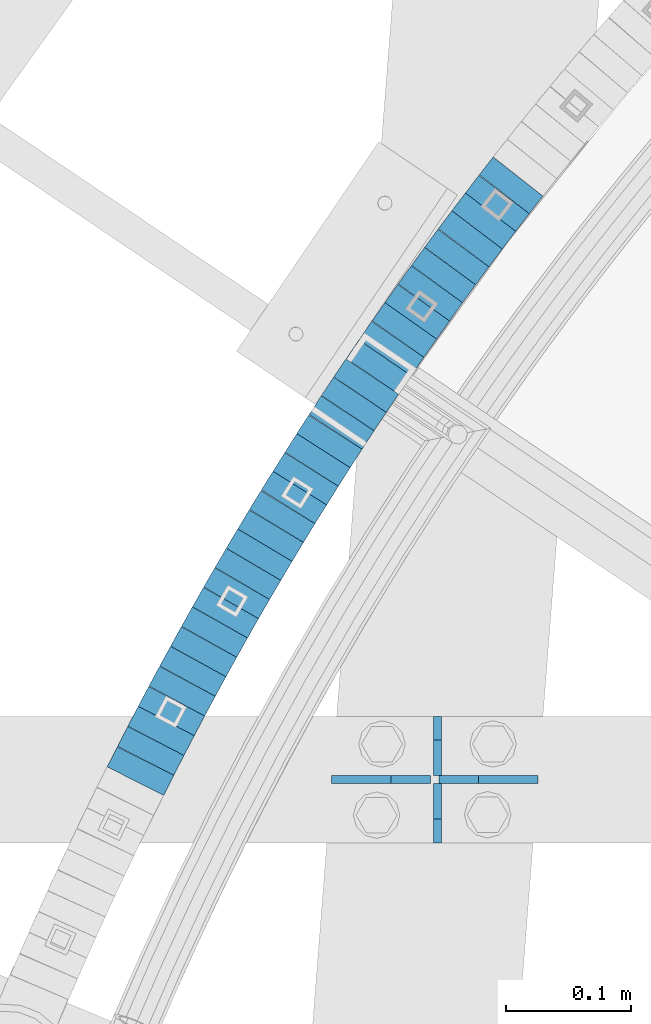
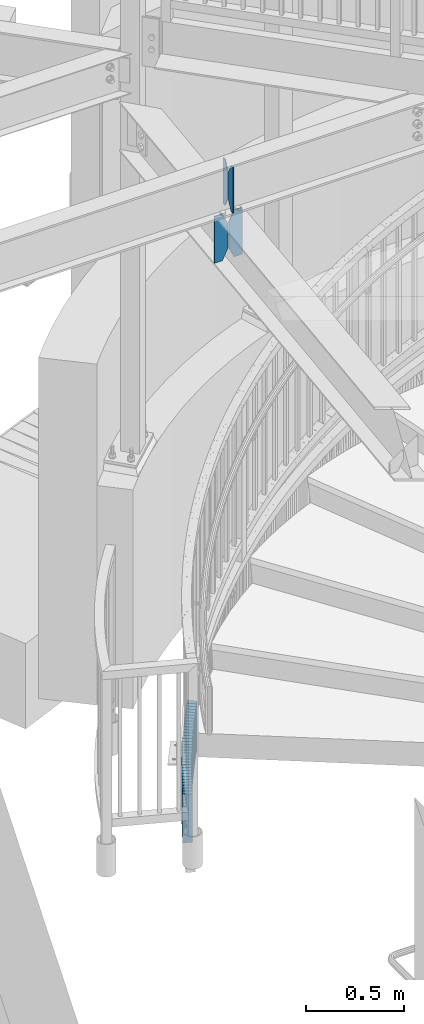
# One storey, part 890 of 975: 36 plates.
"""IFC2X3 building model written with IfcOpenShell, lengths in millimetres."""

from ifc_helpers import new_model, si_unit, frame, origin_with_axes, place, context, subcontext, project, spatial, faceted_brep, material, type_object, element, save


model = new_model("IFC2X3")

# Units and contexts
model_context = context("Model", 3, precision=1e-05, world=origin_with_axes())
body_context = subcontext(model_context, "Body", "Model", "MODEL_VIEW")
ifc_project = project(units=[si_unit("LENGTHUNIT", "METRE", prefix="MILLI"), si_unit("AREAUNIT", "SQUARE_METRE"), si_unit("VOLUMEUNIT", "CUBIC_METRE"), si_unit("MASSUNIT", "GRAM", prefix="KILO"), si_unit("TIMEUNIT", "SECOND"), si_unit("PLANEANGLEUNIT", "RADIAN"), si_unit("SOLIDANGLEUNIT", "STERADIAN"), si_unit("THERMODYNAMICTEMPERATUREUNIT", "DEGREE_CELSIUS"), si_unit("LUMINOUSINTENSITYUNIT", "LUMEN")], contexts=[model_context])

# Site, building, storey
site_placement = place(None, origin_with_axes())
site = spatial("IfcSite", under=ifc_project, at=site_placement, CompositionType="ELEMENT")
building_placement = place(site_placement, origin_with_axes())
building = spatial("IfcBuilding", under=site, at=building_placement, Name="Undefined", CompositionType="ELEMENT")
storey_placement = place(building_placement, origin_with_axes())
storey = spatial("IfcBuildingStorey", under=building, at=storey_placement, Name="Undefined", CompositionType="ELEMENT", Elevation=0.0)

# Plates
ifc_material = material(Name="STEEL/A36")
plate_type_1 = type_object("IfcPlateType", PredefinedType="NOTDEFINED")
plate_1_placement = place(storey_placement, frame((32412.0742550578, 4641.849609375, 3636.9625), z_axis=(0.0, 0.0, 1.0), x_axis=(0.0, 1.0, 0.0)))
element("IfcPlate", 1, at=plate_1_placement, inside=storey, type_object=plate_type_1, material=ifc_material, Name="PLATE", context=body_context, shape_type="Brep", body=[
    faceted_brep([(0.0, -3.17499999999927, 0.0), (0.0, -3.17499999999927, 288.924987792969), (0.0, 3.17499999999927, 288.924987792969), (0.0, 3.17499999999927, 0.0), (19.0499992370605, -3.17499999999927, 288.924987792969), (19.0499992370605, 3.17499999999927, 288.924987792969), (47.625, -3.17499999999927, 227.012489318848), (47.625, 3.17499999999927, 227.012489318848), (47.625, -3.17499999999927, 61.9124984741211), (47.625, 3.17499999999927, 61.9124984741211), (19.0499992370605, -3.17499999999927, 0.0), (19.0499992370605, 3.17499999999927, 0.0)], [[[0, 1, 2, 3]], [[1, 4, 5, 2]], [[4, 6, 7, 5]], [[6, 8, 9, 7]], [[8, 10, 11, 9]], [[10, 0, 3, 11]], [[5, 7, 9, 11, 3, 2]], [[10, 8, 6, 4, 1, 0]]]),
])
plate_2_placement = place(storey_placement, frame((32412.0742550578, 4695.824609375, 3636.9625), z_axis=(0.0, 0.0, 1.0), x_axis=(0.0, 1.0, 0.0)))
element("IfcPlate", 2, at=plate_2_placement, inside=storey, type_object=plate_type_1, material=ifc_material, Name="PLATE", context=body_context, shape_type="Brep", body=[
    faceted_brep([(0.0, -3.17499999999927, 61.9124984741211), (0.0, -3.17499999999927, 227.012489318848), (0.0, 3.17499999999927, 227.012489318848), (0.0, 3.17499999999927, 61.9124984741211), (28.5750007629395, -3.17499999999927, 288.924987792969), (28.5750007629395, 3.17499999999927, 288.924987792969), (47.625, -3.17499999999927, 288.924987792969), (47.625, 3.17499999999927, 288.924987792969), (47.625, -3.17499999999927, 0.0), (47.625, 3.17499999999927, 0.0), (28.5750007629395, -3.17499999999927, 0.0), (28.5750007629395, 3.17499999999927, 0.0)], [[[0, 1, 2, 3]], [[1, 4, 5, 2]], [[4, 6, 7, 5]], [[6, 8, 9, 7]], [[8, 10, 11, 9]], [[10, 0, 3, 11]], [[5, 7, 9, 11, 3, 2]], [[10, 8, 6, 4, 1, 0]]]),
])
plate_type_2 = type_object("IfcPlateType", PredefinedType="NOTDEFINED")
plate_3_placement = place(storey_placement, frame((32492.7576513405, 4692.64926467403, 3324.225), z_axis=(0.0, 0.0, 1.0), x_axis=(-0.999999999991335, 4.16299999770227e-06, 0.0)))
element("IfcPlate", 3, at=plate_3_placement, inside=storey, type_object=plate_type_2, material=ifc_material, Name="PLATE", context=body_context, shape_type="Brep", body=[
    faceted_brep([(0.0, -3.17499999999927, 0.0), (0.0, -3.17499999999973, 292.100006103516), (3.63797880709171e-12, 3.17500000000018, 292.100006103516), (0.0, 3.17499999999927, 0.0), (47.6250000000618, -3.17500000000382, 292.100006103516), (47.6250000000691, 3.17499999999654, 292.100006103516), (79.3750000001091, -3.175000000007, 227.012504577637), (79.3750000001164, 3.17499999999336, 227.012504577637), (79.3750000001091, -3.175000000007, 65.0875015258775), (79.3750000001164, 3.17499999999336, 65.0875015258775), (47.625, -3.17499999999927, 0.0), (47.625, 3.17499999999927, 0.0)], [[[0, 1, 2, 3]], [[1, 4, 5, 2]], [[4, 6, 7, 5]], [[6, 8, 9, 7]], [[8, 10, 11, 9]], [[10, 0, 3, 11]], [[5, 7, 9, 11, 3, 2]], [[10, 8, 6, 4, 1, 0]]]),
])
plate_4_placement = place(storey_placement, frame((32406.5178284442, 4692.6496236632, 3324.225), z_axis=(0.0, 0.0, 1.0), x_axis=(-0.999999999991335, 4.16299999770227e-06, 0.0)))
element("IfcPlate", 4, at=plate_4_placement, inside=storey, type_object=plate_type_2, material=ifc_material, Name="PLATE", context=body_context, shape_type="Brep", body=[
    faceted_brep([(-3.63797880709171e-12, -3.17499999999973, 65.0875015258789), (0.0, -3.17499999999927, 227.012489318848), (0.0, 3.17499999999927, 227.012489318848), (0.0, 3.17500000000018, 65.0875015258789), (31.75000000004, -3.17500000000246, 292.100006103516), (31.7500000000473, 3.17499999999791, 292.100006103516), (79.3750000001055, -3.175000000007, 292.100006103516), (79.3750000001128, 3.17499999999336, 292.100006103516), (79.3750000001055, -3.175000000007, 0.0), (79.3750000001128, 3.17499999999336, 0.0), (31.75000000004, -3.17500000000246, 0.0), (31.7500000000473, 3.17499999999791, 0.0)], [[[0, 1, 2, 3]], [[1, 4, 5, 2]], [[4, 6, 7, 5]], [[6, 8, 9, 7]], [[8, 10, 11, 9]], [[10, 0, 3, 11]], [[5, 7, 9, 11, 3, 2]], [[10, 8, 6, 4, 1, 0]]]),
])
plate_type_3 = type_object("IfcPlateType", PredefinedType="NOTDEFINED")
plate_5_placement = place(storey_placement, frame((32465.6705449719, 5162.5040986631, 235.199999991737), z_axis=(0.61510132921725, 0.788448067278481, 0.0), x_axis=(0.0, 0.0, -1.0)))
element("IfcPlate", 5, at=plate_5_placement, inside=storey, type_object=plate_type_3, material=ifc_material, Name="WALL", context=body_context, shape_type="Brep", body=[
    faceted_brep([(0.0, -25.3999999999724, -1.81898940354586e-11), (-5.69999980926514, -25.4000000000233, 17.8807163238162), (-5.69999980926514, 25.400000000096, 17.8807163239253), (0.0, 25.3999999999869, 1.45519152283669e-11), (299.100006103516, -25.4000000000233, 17.8807163238162), (299.100006103516, 25.400000000096, 17.8807163239253), (304.799987792969, -25.3999999999724, -1.81898940354586e-11), (304.799987792969, 25.3999999999869, 1.45519152283669e-11)], [[[0, 1, 2, 3]], [[1, 4, 5, 2]], [[4, 6, 7, 5]], [[6, 0, 3, 7]], [[5, 7, 3, 2]], [[6, 4, 1, 0]]]),
])
plate_6_placement = place(storey_placement, frame((32454.6800944497, 5148.05685866956, 229.499999991737), z_axis=(0.60536747118571, 0.795946119300935, -2.19542926060967e-11), x_axis=(0.0, 0.0, -1.0)))
element("IfcPlate", 6, at=plate_6_placement, inside=storey, type_object=plate_type_3, material=ifc_material, Name="WALL", context=body_context, shape_type="Brep", body=[
    faceted_brep([(0.0, -25.3999999999724, -1.81898940354586e-11), (-5.69999980926514, -25.3999999999614, 17.8370399475461), (-5.69999980926514, 25.4000000000487, 17.8370399475571), (0.0, 25.3999999999869, 1.45519152283669e-11), (299.100006103516, -25.3999999999614, 17.8370399475461), (299.100006103516, 25.4000000000487, 17.8370399475571), (304.799987792969, -25.3999999999724, -1.81898940354586e-11), (304.799987792969, 25.3999999999869, 1.45519152283669e-11)], [[[0, 1, 2, 3]], [[1, 4, 5, 2]], [[4, 6, 7, 5]], [[6, 0, 3, 7]], [[5, 7, 3, 2]], [[6, 4, 1, 0]]]),
])
plate_7_placement = place(storey_placement, frame((32443.8800944485, 5133.85685866933, 223.699999991737), z_axis=(0.60536747118571, 0.795946119300935, -2.19542926060967e-11), x_axis=(0.0, 0.0, -1.0)))
element("IfcPlate", 7, at=plate_7_placement, inside=storey, type_object=plate_type_3, material=ifc_material, Name="WALL", context=body_context, shape_type="Brep", body=[
    faceted_brep([(0.0, -25.3999999999724, -1.81898940354586e-11), (-5.80000019073486, -25.3999999999578, 17.8370399475461), (-5.80000019073486, 25.4000000000524, 17.8370399475607), (0.0, 25.3999999999869, 1.45519152283669e-11), (299.0, -25.3999999999578, 17.8370399475461), (299.0, 25.4000000000524, 17.8370399475607), (304.799987792969, -25.3999999999724, -1.81898940354586e-11), (304.799987792969, 25.3999999999869, 1.45519152283669e-11)], [[[0, 1, 2, 3]], [[1, 4, 5, 2]], [[4, 6, 7, 5]], [[6, 0, 3, 7]], [[5, 7, 3, 2]], [[6, 4, 1, 0]]]),
])
plate_8_placement = place(storey_placement, frame((32433.0282662671, 5119.48847479921, 217.999999991737), z_axis=(0.602675192946082, 0.797986598764292, -3.14994395012037e-11), x_axis=(0.0, 0.0, -1.0)))
element("IfcPlate", 8, at=plate_8_placement, inside=storey, type_object=plate_type_3, material=ifc_material, Name="WALL", context=body_context, shape_type="Brep", body=[
    faceted_brep([(0.0, -25.3999999999724, -1.81898940354586e-11), (-5.69999980926514, -25.4000000000087, 17.9245643615468), (-5.69999980926514, 25.3999999999687, 17.9245643615541), (0.0, 25.3999999999869, 1.45519152283669e-11), (299.100006103516, -25.4000000000087, 17.9245643615468), (299.100006103516, 25.3999999999687, 17.9245643615541), (304.799987792969, -25.3999999999724, -1.81898940354586e-11), (304.799987792969, 25.3999999999869, 1.45519152283669e-11)], [[[0, 1, 2, 3]], [[1, 4, 5, 2]], [[4, 6, 7, 5]], [[6, 0, 3, 7]], [[5, 7, 3, 2]], [[6, 4, 1, 0]]]),
])
plate_9_placement = place(storey_placement, frame((32422.2415690206, 5104.83808757393, 212.299999991737), z_axis=(0.592817428552363, 0.805336883797435, 3.6648793866334e-10), x_axis=(0.0, 0.0, -1.0)))
element("IfcPlate", 9, at=plate_9_placement, inside=storey, type_object=plate_type_3, material=ifc_material, Name="WALL", context=body_context, shape_type="Brep", body=[
    faceted_brep([(0.0, -25.3999999999724, -1.81898940354586e-11), (-5.69999980926514, -25.4000000000233, 17.8807163238162), (-5.69999980926514, 25.400000000096, 17.8807163239253), (0.0, 25.3999999999869, 1.45519152283669e-11), (299.100006103516, -25.4000000000233, 17.8807163238162), (299.100006103516, 25.400000000096, 17.8807163239253), (304.799987792969, -25.3999999999724, -1.81898940354586e-11), (304.799987792969, 25.3999999999869, 1.45519152283669e-11)], [[[0, 1, 2, 3]], [[1, 4, 5, 2]], [[4, 6, 7, 5]], [[6, 0, 3, 7]], [[5, 7, 3, 2]], [[6, 4, 1, 0]]]),
])
plate_10_placement = place(storey_placement, frame((32411.6737346072, 5090.34549769482, 206.499999991737), z_axis=(0.589172157259019, 0.808007530355228, 0.0), x_axis=(0.0, 0.0, -1.0)))
element("IfcPlate", 10, at=plate_10_placement, inside=storey, type_object=plate_type_3, material=ifc_material, Name="WALL", context=body_context, shape_type="Brep", body=[
    faceted_brep([(0.0, -25.3999999999724, -1.81898940354586e-11), (-5.80000019073486, -25.400000000016, 17.8193721771022), (-5.80000019073486, 25.4000000001179, 17.8193721772113), (0.0, 25.3999999999869, 1.45519152283669e-11), (299.0, -25.400000000016, 17.8193721771022), (299.0, 25.4000000001179, 17.8193721772113), (304.799987792969, -25.3999999999724, -1.81898940354586e-11), (304.799987792969, 25.3999999999869, 1.45519152283669e-11)], [[[0, 1, 2, 3]], [[1, 4, 5, 2]], [[4, 6, 7, 5]], [[6, 0, 3, 7]], [[5, 7, 3, 2]], [[6, 4, 1, 0]]]),
])
plate_11_placement = place(storey_placement, frame((32401.0761197999, 5075.61070049881, 200.799999991737), z_axis=(0.583865181033086, 0.811850633046007, 0.0), x_axis=(0.0, 0.0, -1.0)))
element("IfcPlate", 11, at=plate_11_placement, inside=storey, type_object=plate_type_3, material=ifc_material, Name="WALL", context=body_context, shape_type="Brep", body=[
    faceted_brep([(0.0, -25.3999999999724, -1.81898940354586e-11), (-5.69999980926514, -25.3999999999141, 17.9836044311924), (-5.69999980926514, 25.3999999999432, 17.983604431116), (0.0, 25.3999999999869, 1.45519152283669e-11), (299.100006103516, -25.3999999999141, 17.9836044311924), (299.100006103516, 25.3999999999432, 17.983604431116), (304.799987792969, -25.3999999999724, -1.81898940354586e-11), (304.799987792969, 25.3999999999869, 1.45519152283669e-11)], [[[0, 1, 2, 3]], [[1, 4, 5, 2]], [[4, 6, 7, 5]], [[6, 0, 3, 7]], [[5, 7, 3, 2]], [[6, 4, 1, 0]]]),
])
plate_12_placement = place(storey_placement, frame((32390.642203225, 5060.82269638001, 194.999999991737), z_axis=(0.576463443844703, 0.817122939288027, 9.34501258598175e-11), x_axis=(0.0, 0.0, -1.0)))
element("IfcPlate", 12, at=plate_12_placement, inside=storey, type_object=plate_type_3, material=ifc_material, Name="WALL", context=body_context, shape_type="Brep", body=[
    faceted_brep([(0.0, -25.3999999999724, -1.81898940354586e-11), (-5.80000019073486, -25.4000000000524, 17.8675689696865), (-5.80000019073486, 25.4000000000888, 17.867568969803), (0.0, 25.3999999999869, 1.45519152283669e-11), (299.0, -25.4000000000524, 17.8675689696865), (299.0, 25.4000000000888, 17.867568969803), (304.799987792969, -25.3999999999724, -1.81898940354586e-11), (304.799987792969, 25.3999999999869, 1.45519152283669e-11)], [[[0, 1, 2, 3]], [[1, 4, 5, 2]], [[4, 6, 7, 5]], [[6, 0, 3, 7]], [[5, 7, 3, 2]], [[6, 4, 1, 0]]]),
])
plate_13_placement = place(storey_placement, frame((32380.3422032245, 5046.22269637971, 189.299999991737), z_axis=(0.576463443844703, 0.817122939288027, 9.34501258598175e-11), x_axis=(0.0, 0.0, -1.0)))
element("IfcPlate", 13, at=plate_13_placement, inside=storey, type_object=plate_type_3, material=ifc_material, Name="WALL", context=body_context, shape_type="Brep", body=[
    faceted_brep([(0.0, -25.3999999999724, -1.81898940354586e-11), (-5.69999980926514, -25.4000000000524, 17.8734436034756), (-5.69999980926514, 25.4000000000888, 17.8734436035884), (0.0, 25.3999999999869, 1.45519152283669e-11), (299.100006103516, -25.4000000000524, 17.8734436034756), (299.100006103516, 25.4000000000888, 17.8734436035884), (304.799987792969, -25.3999999999724, -1.81898940354586e-11), (304.799987792969, 25.3999999999869, 1.45519152283669e-11)], [[[0, 1, 2, 3]], [[1, 4, 5, 2]], [[4, 6, 7, 5]], [[6, 0, 3, 7]], [[5, 7, 3, 2]], [[6, 4, 1, 0]]]),
])
plate_14_placement = place(storey_placement, frame((32369.9829673841, 5031.19433683429, 183.599999991737), z_axis=(0.567472910754303, 0.823392066733727, -3.24725988321006e-11), x_axis=(0.0, 0.0, -1.0)))
element("IfcPlate", 14, at=plate_14_placement, inside=storey, type_object=plate_type_3, material=ifc_material, Name="WALL", context=body_context, shape_type="Brep", body=[
    faceted_brep([(0.0, -25.3999999999724, -1.81898940354586e-11), (-5.69999980926514, -25.3999999999505, 17.9744262695713), (-5.69999980926514, 25.4000000000524, 17.9744262695494), (0.0, 25.3999999999869, 1.45519152283669e-11), (299.100006103516, -25.3999999999505, 17.9744262695713), (299.100006103516, 25.4000000000524, 17.9744262695494), (304.799987792969, -25.3999999999724, -1.81898940354586e-11), (304.799987792969, 25.3999999999869, 1.45519152283669e-11)], [[[0, 1, 2, 3]], [[1, 4, 5, 2]], [[4, 6, 7, 5]], [[6, 0, 3, 7]], [[5, 7, 3, 2]], [[6, 4, 1, 0]]]),
])
plate_15_placement = place(storey_placement, frame((32359.8169514321, 5016.29807637485, 177.799999991737), z_axis=(0.563683129387442, 0.825991119591477, -1.78132268047193e-10), x_axis=(0.0, 0.0, -1.0)))
element("IfcPlate", 15, at=plate_15_placement, inside=storey, type_object=plate_type_3, material=ifc_material, Name="WALL", context=body_context, shape_type="Brep", body=[
    faceted_brep([(0.0, -25.3999999999724, -1.81898940354586e-11), (-5.80000019073486, -25.3999999999724, 17.9212169647508), (-5.80000019073486, 25.399999999885, 17.9212169646526), (0.0, 25.3999999999869, 1.45519152283669e-11), (299.0, -25.3999999999724, 17.9212169647508), (299.0, 25.399999999885, 17.9212169646526), (304.799987792969, -25.3999999999724, -1.81898940354586e-11), (304.799987792969, 25.3999999999869, 1.45519152283669e-11)], [[[0, 1, 2, 3]], [[1, 4, 5, 2]], [[4, 6, 7, 5]], [[6, 0, 3, 7]], [[5, 7, 3, 2]], [[6, 4, 1, 0]]]),
])
plate_16_placement = place(storey_placement, frame((32349.9075993516, 5001.53650847321, 172.099999991737), z_axis=(0.557322187932383, 0.830296319899265, 0.0), x_axis=(0.0, 0.0, -1.0)))
element("IfcPlate", 16, at=plate_16_placement, inside=storey, type_object=plate_type_3, material=ifc_material, Name="WALL", context=body_context, shape_type="Brep", body=[
    faceted_brep([(0.0, -25.3999999999724, -1.81898940354586e-11), (-5.69999980926514, -25.4000000000815, 17.5840835570707), (-5.69999980926514, 25.4000000000378, 17.5840835571653), (0.0, 25.3999999999869, 1.45519152283669e-11), (299.100006103516, -25.4000000000815, 17.5840835570707), (299.100006103516, 25.4000000000378, 17.5840835571653), (304.799987792969, -25.3999999999724, -1.81898940354586e-11), (304.799987792969, 25.3999999999869, 1.45519152283669e-11)], [[[0, 1, 2, 3]], [[1, 4, 5, 2]], [[4, 6, 7, 5]], [[6, 0, 3, 7]], [[5, 7, 3, 2]], [[6, 4, 1, 0]]]),
])
plate_17_placement = place(storey_placement, frame((32340.063048401, 4986.76990988377, 166.499999991737), z_axis=(0.55470019603009, 0.832050294467936, -1.48306526170927e-10), x_axis=(0.0, 0.0, -1.0)))
element("IfcPlate", 17, at=plate_17_placement, inside=storey, type_object=plate_type_3, material=ifc_material, Name="WALL", context=body_context, shape_type="Brep", body=[
    faceted_brep([(0.0, -25.3999999999724, -1.81898940354586e-11), (-5.59999990463257, -25.3999999999651, 17.6708793640246), (-5.59999990463257, 25.3999999999942, 17.6708793640119), (0.0, 25.3999999999869, 1.45519152283669e-11), (299.200012207031, -25.3999999999651, 17.6708793640246), (299.200012207031, 25.3999999999942, 17.6708793640119), (304.799987792969, -25.3999999999724, -1.81898940354586e-11), (304.799987792969, 25.3999999999869, 1.45519152283669e-11)], [[[0, 1, 2, 3]], [[1, 4, 5, 2]], [[4, 6, 7, 5]], [[6, 0, 3, 7]], [[5, 7, 3, 2]], [[6, 4, 1, 0]]]),
])
plate_18_placement = place(storey_placement, frame((32330.2532823987, 4971.80385475391, 160.799999991737), z_axis=(0.548162592686164, 0.836371790521167, 0.0), x_axis=(0.0, 0.0, -1.0)))
element("IfcPlate", 18, at=plate_18_placement, inside=storey, type_object=plate_type_3, material=ifc_material, Name="WALL", context=body_context, shape_type="Brep", body=[
    faceted_brep([(0.0, -25.3999999999724, -1.81898940354586e-11), (-5.69999980926514, -25.3999999999724, 17.6954803467033), (-5.69999980926514, 25.4000000000669, 17.6954803467179), (0.0, 25.3999999999869, 1.45519152283669e-11), (299.100006103516, -25.3999999999724, 17.6954803467033), (299.100006103516, 25.4000000000669, 17.6954803467179), (304.799987792969, -25.3999999999724, -1.81898940354586e-11), (304.799987792969, 25.3999999999869, 1.45519152283669e-11)], [[[0, 1, 2, 3]], [[1, 4, 5, 2]], [[4, 6, 7, 5]], [[6, 0, 3, 7]], [[5, 7, 3, 2]], [[6, 4, 1, 0]]]),
])
plate_19_placement = place(storey_placement, frame((32320.5799695242, 4956.63575882982, 155.199999991737), z_axis=(0.537607635043335, 0.843195132067964, 0.0), x_axis=(0.0, 0.0, -1.0)))
element("IfcPlate", 19, at=plate_19_placement, inside=storey, type_object=plate_type_3, material=ifc_material, Name="WALL", context=body_context, shape_type="Brep", body=[
    faceted_brep([(0.0, -25.3999999999724, -1.81898940354586e-11), (-5.59999990463257, -25.3999999999651, 17.6708793640246), (-5.59999990463257, 25.3999999999942, 17.6708793640119), (0.0, 25.3999999999869, 1.45519152283669e-11), (299.200012207031, -25.3999999999651, 17.6708793640246), (299.200012207031, 25.3999999999942, 17.6708793640119), (304.799987792969, -25.3999999999724, -1.81898940354586e-11), (304.799987792969, 25.3999999999869, 1.45519152283669e-11)], [[[0, 1, 2, 3]], [[1, 4, 5, 2]], [[4, 6, 7, 5]], [[6, 0, 3, 7]], [[5, 7, 3, 2]], [[6, 4, 1, 0]]]),
])
plate_20_placement = place(storey_placement, frame((32311.079969525, 4941.73575882988, 149.499999991737), z_axis=(0.537607635043335, 0.843195132067964, 0.0), x_axis=(0.0, 0.0, -1.0)))
element("IfcPlate", 20, at=plate_20_placement, inside=storey, type_object=plate_type_3, material=ifc_material, Name="WALL", context=body_context, shape_type="Brep", body=[
    faceted_brep([(0.0, -25.3999999999724, -1.81898940354586e-11), (-5.69999980926514, -25.3999999999651, 17.6708793640282), (-5.69999980926514, 25.3999999999942, 17.6708793640191), (0.0, 25.3999999999869, 1.45519152283669e-11), (299.100006103516, -25.3999999999651, 17.6708793640282), (299.100006103516, 25.3999999999942, 17.6708793640191), (304.799987792969, -25.3999999999724, -1.81898940354586e-11), (304.799987792969, 25.3999999999869, 1.45519152283669e-11)], [[[0, 1, 2, 3]], [[1, 4, 5, 2]], [[4, 6, 7, 5]], [[6, 0, 3, 7]], [[5, 7, 3, 2]], [[6, 4, 1, 0]]]),
])
for number, where, z_axis, x_axis, name in (
    (21, (32301.5741065167, 4926.56828370102, 143.799999991737), (0.531014126038605, 0.847362967061611, 0.0), (0.0, 0.0, -1.0), "WALL"),
    (22, (32292.1741065172, 4911.56828370092, 138.099999991737), (0.531014126038605, 0.847362967061611, 0.0), (0.0, 0.0, -1.0), "WALL"),
):
    element("IfcPlate", number, at=place(storey_placement, frame(where, z_axis=z_axis, x_axis=x_axis)), inside=storey, type_object=plate_type_3, material=ifc_material, Name=name, context=body_context, shape_type="Brep", body=[
        faceted_brep([(0.0, -25.3999999999724, -1.81898940354586e-11), (-5.69999980926514, -25.3999999999724, 17.6954803467033), (-5.69999980926514, 25.4000000000669, 17.6954803467179), (0.0, 25.3999999999869, 1.45519152283669e-11), (299.100006103516, -25.3999999999724, 17.6954803467033), (299.100006103516, 25.4000000000669, 17.6954803467179), (304.799987792969, -25.3999999999724, -1.81898940354586e-11), (304.799987792969, 25.3999999999869, 1.45519152283669e-11)], [[[0, 1, 2, 3]], [[1, 4, 5, 2]], [[4, 6, 7, 5]], [[6, 0, 3, 7]], [[5, 7, 3, 2]], [[6, 4, 1, 0]]]),
    ])
plate_21_placement = place(storey_placement, frame((32282.8060323355, 4896.19629051522, 132.399999991737), z_axis=(0.520305732901598, 0.853980060838502, 0.0), x_axis=(0.0, 0.0, -1.0)))
element("IfcPlate", 23, at=plate_21_placement, inside=storey, type_object=plate_type_3, material=ifc_material, Name="WALL", context=body_context, shape_type="Brep", body=[
    faceted_brep([(0.0, -25.3999999999724, -1.81898940354586e-11), (-5.69999980926514, -25.4000000001179, 17.6819114684386), (-5.69999980926514, 25.400000000016, 17.681911468515), (0.0, 25.3999999999869, 1.45519152283669e-11), (299.100006103516, -25.4000000001179, 17.6819114684386), (299.100006103516, 25.400000000016, 17.681911468515), (304.799987792969, -25.3999999999724, -1.81898940354586e-11), (304.799987792969, 25.3999999999869, 1.45519152283669e-11)], [[[0, 1, 2, 3]], [[1, 4, 5, 2]], [[4, 6, 7, 5]], [[6, 0, 3, 7]], [[5, 7, 3, 2]], [[6, 4, 1, 0]]]),
])
plate_22_placement = place(storey_placement, frame((32273.6041650633, 4880.82762644641, 126.799999991737), z_axis=(0.513665415235311, 0.857990583393044, 0.0), x_axis=(0.0, 0.0, -1.0)))
element("IfcPlate", 24, at=plate_22_placement, inside=storey, type_object=plate_type_3, material=ifc_material, Name="WALL", context=body_context, shape_type="Brep", body=[
    faceted_brep([(0.0, -25.3999999999724, -1.81898940354586e-11), (-5.59999990463257, -25.3999999999141, 17.7158126831655), (-5.59999990463257, 25.3999999999724, 17.71581268308), (0.0, 25.3999999999869, 1.45519152283669e-11), (299.200012207031, -25.3999999999141, 17.7158126831655), (299.200012207031, 25.3999999999724, 17.71581268308), (304.799987792969, -25.3999999999724, -1.81898940354586e-11), (304.799987792969, 25.3999999999869, 1.45519152283669e-11)], [[[0, 1, 2, 3]], [[1, 4, 5, 2]], [[4, 6, 7, 5]], [[6, 0, 3, 7]], [[5, 7, 3, 2]], [[6, 4, 1, 0]]]),
])
plate_23_placement = place(storey_placement, frame((32264.46660854, 4865.4646888165, 121.099999991737), z_axis=(0.511187555792531, 0.85946918665119, 0.0), x_axis=(0.0, 0.0, -1.0)))
element("IfcPlate", 25, at=plate_23_placement, inside=storey, type_object=plate_type_3, material=ifc_material, Name="WALL", context=body_context, shape_type="Brep", body=[
    faceted_brep([(0.0, -25.3999999999724, -1.81898940354586e-11), (-5.69999980926514, -25.4000000000378, 17.8044929504049), (-5.69999980926514, 25.4000000000233, 17.8044929504613), (0.0, 25.3999999999869, 1.45519152283669e-11), (299.100006103516, -25.4000000000378, 17.8044929504049), (299.100006103516, 25.4000000000233, 17.8044929504613), (304.799987792969, -25.3999999999724, -1.81898940354586e-11), (304.799987792969, 25.3999999999869, 1.45519152283669e-11)], [[[0, 1, 2, 3]], [[1, 4, 5, 2]], [[4, 6, 7, 5]], [[6, 0, 3, 7]], [[5, 7, 3, 2]], [[6, 4, 1, 0]]]),
])
plate_24_placement = place(storey_placement, frame((32255.4039968214, 4850.05883612392, 115.399999991737), z_axis=(0.507020126956711, 0.861934214926407, 0.0), x_axis=(0.0, 0.0, -1.0)))
element("IfcPlate", 26, at=plate_24_placement, inside=storey, type_object=plate_type_3, material=ifc_material, Name="WALL", context=body_context, shape_type="Brep", body=[
    faceted_brep([(0.0, -25.3999999999724, -1.81898940354586e-11), (-5.69999980926514, -25.3999999999869, 17.750774383554), (-5.69999980926514, 25.3999999999432, 17.750774383534), (0.0, 25.3999999999869, 1.45519152283669e-11), (299.100006103516, -25.3999999999869, 17.750774383554), (299.100006103516, 25.3999999999432, 17.750774383534), (304.799987792969, -25.3999999999724, -1.81898940354586e-11), (304.799987792969, 25.3999999999869, 1.45519152283669e-11)], [[[0, 1, 2, 3]], [[1, 4, 5, 2]], [[4, 6, 7, 5]], [[6, 0, 3, 7]], [[5, 7, 3, 2]], [[6, 4, 1, 0]]]),
])
plate_25_placement = place(storey_placement, frame((32246.4055277791, 4834.48995497786, 109.699999991737), z_axis=(0.500371262938832, 0.865810948894156, 0.0), x_axis=(0.0, 0.0, -1.0)))
element("IfcPlate", 27, at=plate_25_placement, inside=storey, type_object=plate_type_3, material=ifc_material, Name="WALL", context=body_context, shape_type="Brep", body=[
    faceted_brep([(0.0, -25.3999999999724, -1.81898940354586e-11), (-5.69999980926514, -25.4000000000306, 17.7867927551051), (-5.69999980926514, 25.4000000000888, 17.7867927551815), (0.0, 25.3999999999869, 1.45519152283669e-11), (299.100006103516, -25.4000000000306, 17.7867927551051), (299.100006103516, 25.4000000000888, 17.7867927551815), (304.799987792969, -25.3999999999724, -1.81898940354586e-11), (304.799987792969, 25.3999999999869, 1.45519152283669e-11)], [[[0, 1, 2, 3]], [[1, 4, 5, 2]], [[4, 6, 7, 5]], [[6, 0, 3, 7]], [[5, 7, 3, 2]], [[6, 4, 1, 0]]]),
])
plate_26_placement = place(storey_placement, frame((32237.5087572052, 4818.82101808086, 103.999999991737), z_axis=(0.493720204004982, 0.869620814008772, 0.0), x_axis=(0.0, 0.0, -1.0)))
element("IfcPlate", 28, at=plate_26_placement, inside=storey, type_object=plate_type_3, material=ifc_material, Name="WALL", context=body_context, shape_type="Brep", body=[
    faceted_brep([(0.0, -25.3999999999724, -1.81898940354586e-11), (-5.69999980926514, -25.4000000000669, 17.8227386474155), (-5.69999980926514, 25.3999999999724, 17.8227386474609), (0.0, 25.3999999999869, 1.45519152283669e-11), (299.100006103516, -25.4000000000669, 17.8227386474155), (299.100006103516, 25.3999999999724, 17.8227386474609), (304.799987792969, -25.3999999999724, -1.81898940354586e-11), (304.799987792969, 25.3999999999869, 1.45519152283669e-11)], [[[0, 1, 2, 3]], [[1, 4, 5, 2]], [[4, 6, 7, 5]], [[6, 0, 3, 7]], [[5, 7, 3, 2]], [[6, 4, 1, 0]]]),
])
plate_27_placement = place(storey_placement, frame((32228.7476676591, 4803.21280146023, 98.1999999917371), z_axis=(0.489459707131162, 0.872025914233675, 0.0), x_axis=(0.0, 0.0, -1.0)))
element("IfcPlate", 29, at=plate_27_placement, inside=storey, type_object=plate_type_3, material=ifc_material, Name="WALL", context=body_context, shape_type="Brep", body=[
    faceted_brep([(0.0, -25.3999999999724, -1.81898940354586e-11), (-5.80000019073486, -25.400000000016, 17.7730140686072), (-5.80000019073486, 25.4000000000742, 17.7730140686326), (0.0, 25.3999999999869, 1.45519152283669e-11), (299.0, -25.400000000016, 17.7730140686072), (299.0, 25.4000000000742, 17.7730140686326), (304.799987792969, -25.3999999999724, -1.81898940354586e-11), (304.799987792969, 25.3999999999869, 1.45519152283669e-11)], [[[0, 1, 2, 3]], [[1, 4, 5, 2]], [[4, 6, 7, 5]], [[6, 0, 3, 7]], [[5, 7, 3, 2]], [[6, 4, 1, 0]]]),
])
plate_28_placement = place(storey_placement, frame((32220.0532946027, 4787.44314982586, 92.4999999917371), z_axis=(0.482780509040982, 0.875741388818714, 7.89789282862329e-11), x_axis=(0.0, 0.0, -1.0)))
element("IfcPlate", 30, at=plate_28_placement, inside=storey, type_object=plate_type_3, material=ifc_material, Name="WALL", context=body_context, shape_type="Brep", body=[
    faceted_brep([(0.0, -25.3999999999724, -1.81898940354586e-11), (-5.69999980926514, -25.4000000001106, 17.8134784697704), (-5.69999980926514, 25.4000000000306, 17.8134784698614), (0.0, 25.3999999999869, 1.45519152283669e-11), (299.100006103516, -25.4000000001106, 17.8134784697704), (299.100006103516, 25.4000000000306, 17.8134784698614), (304.799987792969, -25.3999999999724, -1.81898940354586e-11), (304.799987792969, 25.3999999999869, 1.45519152283669e-11)], [[[0, 1, 2, 3]], [[1, 4, 5, 2]], [[4, 6, 7, 5]], [[6, 0, 3, 7]], [[5, 7, 3, 2]], [[6, 4, 1, 0]]]),
])
plate_29_placement = place(storey_placement, frame((32211.4203040695, 4771.68311519749, 86.7999999917372), z_axis=(0.480416940883697, 0.877040228787683, 0.0), x_axis=(0.0, 0.0, -1.0)))
element("IfcPlate", 31, at=plate_29_placement, inside=storey, type_object=plate_type_3, material=ifc_material, Name="WALL", context=body_context, shape_type="Brep", body=[
    faceted_brep([(0.0, -25.3999999999724, -1.81898940354586e-11), (-5.69999980926514, -25.3999999999578, 17.9047489166387), (-5.69999980926514, 25.3999999999069, 17.9047489165732), (0.0, 25.3999999999869, 1.45519152283669e-11), (299.100006103516, -25.3999999999578, 17.9047489166387), (299.100006103516, 25.3999999999069, 17.9047489165732), (304.799987792969, -25.3999999999724, -1.81898940354586e-11), (304.799987792969, 25.3999999999869, 1.45519152283669e-11)], [[[0, 1, 2, 3]], [[1, 4, 5, 2]], [[4, 6, 7, 5]], [[6, 0, 3, 7]], [[5, 7, 3, 2]], [[6, 4, 1, 0]]]),
])
plate_30_placement = place(storey_placement, frame((32202.8286156251, 4755.7142171393, 81.0999999917372), z_axis=(0.473767410843312, 0.880650010175906, 7.15508576831779e-11), x_axis=(0.0, 0.0, -1.0)))
element("IfcPlate", 32, at=plate_30_placement, inside=storey, type_object=plate_type_3, material=ifc_material, Name="WALL", context=body_context, shape_type="Brep", body=[
    faceted_brep([(0.0, -25.3999999999724, -1.81898940354586e-11), (-5.69999980926514, -25.399999999885, 17.9387855530204), (-5.69999980926514, 25.3999999999651, 17.9387855529603), (0.0, 25.3999999999869, 1.45519152283669e-11), (299.100006103516, -25.399999999885, 17.9387855530204), (299.100006103516, 25.3999999999651, 17.9387855529603), (304.799987792969, -25.3999999999724, -1.81898940354586e-11), (304.799987792969, 25.3999999999869, 1.45519152283669e-11)], [[[0, 1, 2, 3]], [[1, 4, 5, 2]], [[4, 6, 7, 5]], [[6, 0, 3, 7]], [[5, 7, 3, 2]], [[6, 4, 1, 0]]]),
])
plate_31_placement = place(storey_placement, frame((32194.4109484774, 4739.69288392532, 75.2999999917372), z_axis=(0.465053504492513, 0.885282575203665, 1.73736225406174e-10), x_axis=(0.0, 0.0, -1.0)))
element("IfcPlate", 33, at=plate_31_placement, inside=storey, type_object=plate_type_3, material=ifc_material, Name="WALL", context=body_context, shape_type="Brep", body=[
    faceted_brep([(0.0, -25.3999999999724, -1.81898940354586e-11), (-5.80000019073486, -25.3999999999869, 17.8549709320232), (-5.80000019073486, 25.3999999999432, 17.8549709319796), (0.0, 25.3999999999869, 1.45519152283669e-11), (299.0, -25.3999999999869, 17.8549709320232), (299.0, 25.3999999999432, 17.8549709319796), (304.799987792969, -25.3999999999724, -1.81898940354586e-11), (304.799987792969, 25.3999999999869, 1.45519152283669e-11)], [[[0, 1, 2, 3]], [[1, 4, 5, 2]], [[4, 6, 7, 5]], [[6, 0, 3, 7]], [[5, 7, 3, 2]], [[6, 4, 1, 0]]]),
])
plate_32_placement = place(storey_placement, frame((32186.0803963805, 4723.73454091874, 69.5999999917372), z_axis=(0.46275653681341, 0.886485413098523, -2.18433342524804e-10), x_axis=(0.0, 0.0, -1.0)))
element("IfcPlate", 34, at=plate_32_placement, inside=storey, type_object=plate_type_3, material=ifc_material, Name="WALL", context=body_context, shape_type="Brep", body=[
    faceted_brep([(0.0, -25.3999999999724, -1.81898940354586e-11), (-5.69999980926514, -25.399999999885, 17.9387855530204), (-5.69999980926514, 25.3999999999651, 17.9387855529603), (0.0, 25.3999999999869, 1.45519152283669e-11), (299.100006103516, -25.399999999885, 17.9387855530204), (299.100006103516, 25.3999999999651, 17.9387855529603), (304.799987792969, -25.3999999999724, -1.81898940354586e-11), (304.799987792969, 25.3999999999869, 1.45519152283669e-11)], [[[0, 1, 2, 3]], [[1, 4, 5, 2]], [[4, 6, 7, 5]], [[6, 0, 3, 7]], [[5, 7, 3, 2]], [[6, 4, 1, 0]]]),
])
plate_33_placement = place(storey_placement, frame((32177.8224291293, 4707.72282134567, 63.7999999917372), z_axis=(0.458358127885098, 0.888767588631397, -2.12935447052587e-11), x_axis=(0.0, 0.0, -1.0)))
element("IfcPlate", 35, at=plate_33_placement, inside=storey, type_object=plate_type_3, material=ifc_material, Name="WALL", context=body_context, shape_type="Brep", body=[
    faceted_brep([(0.0, -25.3999999999724, -1.81898940354586e-11), (-5.80000019073486, -25.4000000000378, 17.8932952880568), (-5.80000019073486, 25.4000000001179, 17.8932952881351), (0.0, 25.3999999999869, 1.45519152283669e-11), (299.0, -25.4000000000378, 17.8932952880568), (299.0, 25.4000000001179, 17.8932952881351), (304.799987792969, -25.3999999999724, -1.81898940354586e-11), (304.799987792969, 25.3999999999869, 1.45519152283669e-11)], [[[0, 1, 2, 3]], [[1, 4, 5, 2]], [[4, 6, 7, 5]], [[6, 0, 3, 7]], [[5, 7, 3, 2]], [[6, 4, 1, 0]]]),
])
plate_34_placement = place(storey_placement, frame((32169.6069317445, 4691.39608839978, 58.0999999917372), z_axis=(0.449431633893288, 0.893314729787889, 0.0), x_axis=(0.0, 0.0, -1.0)))
element("IfcPlate", 36, at=plate_34_placement, inside=storey, type_object=plate_type_3, material=ifc_material, Name="WALL", context=body_context, shape_type="Brep", body=[
    faceted_brep([(0.0, -25.3999999999724, -1.81898940354586e-11), (-5.69999980926514, -25.3999999999141, 18.0227642059708), (-5.69999980926514, 25.4000000000306, 18.0227642059454), (0.0, 25.3999999999869, 1.45519152283669e-11), (299.100006103516, -25.3999999999141, 18.0227642059708), (299.100006103516, 25.4000000000306, 18.0227642059454), (304.799987792969, -25.3999999999724, -1.81898940354586e-11), (304.799987792969, 25.3999999999869, 1.45519152283669e-11)], [[[0, 1, 2, 3]], [[1, 4, 5, 2]], [[4, 6, 7, 5]], [[6, 0, 3, 7]], [[5, 7, 3, 2]], [[6, 4, 1, 0]]]),
])

save(model, "model.ifc")
